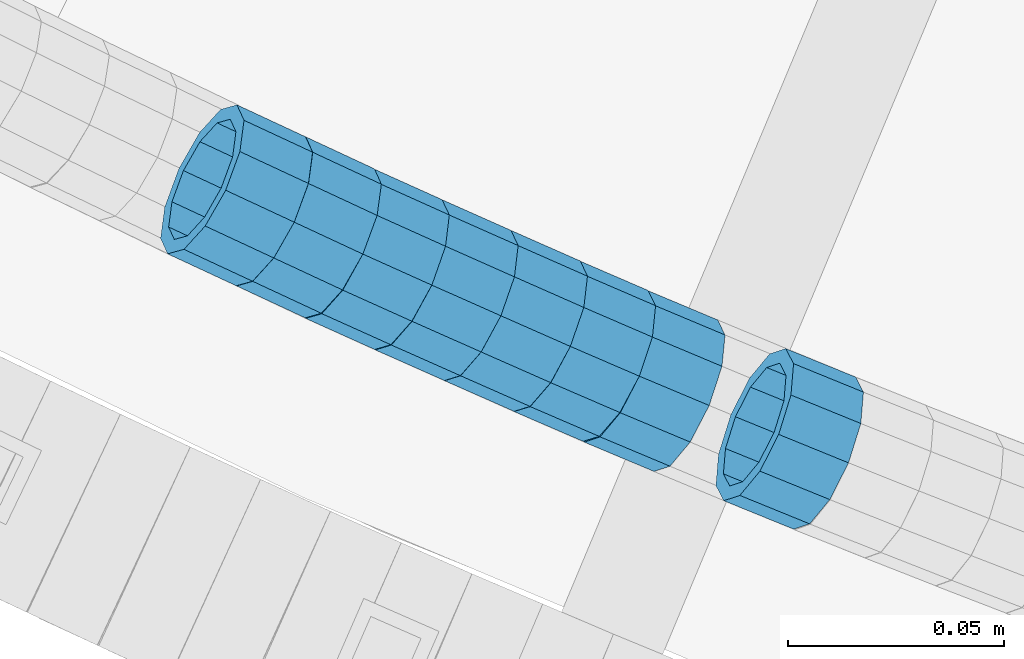
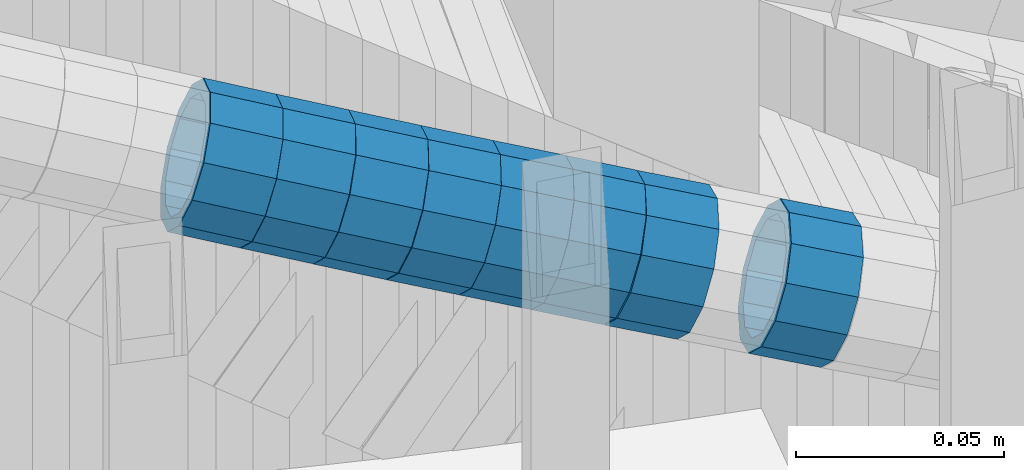
# One storey, part 648 of 975: 8 beams.
"""IFC2X3 building model written with IfcOpenShell, lengths in millimetres."""

from ifc_helpers import new_model, si_unit, frame, origin_with_axes, place, context, subcontext, project, spatial, faceted_brep, material, type_object, element, save


model = new_model("IFC2X3")

# Units and contexts
model_context = context("Model", 3, precision=1e-05, world=origin_with_axes())
body_context = subcontext(model_context, "Body", "Model", "MODEL_VIEW")
ifc_project = project(units=[si_unit("LENGTHUNIT", "METRE", prefix="MILLI"), si_unit("AREAUNIT", "SQUARE_METRE"), si_unit("VOLUMEUNIT", "CUBIC_METRE"), si_unit("MASSUNIT", "GRAM", prefix="KILO"), si_unit("TIMEUNIT", "SECOND"), si_unit("PLANEANGLEUNIT", "RADIAN"), si_unit("SOLIDANGLEUNIT", "STERADIAN"), si_unit("THERMODYNAMICTEMPERATUREUNIT", "DEGREE_CELSIUS"), si_unit("LUMINOUSINTENSITYUNIT", "LUMEN")], contexts=[model_context])

# Site, building, storey
site_placement = place(None, origin_with_axes())
site = spatial("IfcSite", under=ifc_project, at=site_placement, CompositionType="ELEMENT")
building_placement = place(site_placement, origin_with_axes())
building = spatial("IfcBuilding", under=site, at=building_placement, Name="Undefined", CompositionType="ELEMENT")
storey_placement = place(building_placement, origin_with_axes())
storey = spatial("IfcBuildingStorey", under=building, at=storey_placement, Name="Undefined", CompositionType="ELEMENT", Elevation=0.0)

# Beams
ifc_material = material()
beam_type = type_object("IfcBeamType", PredefinedType="NOTDEFINED")
beam_1_placement = place(storey_placement, frame((33541.3736434403, 884.03128961112, 4612.91343516353), z_axis=(0.421948777550613, 0.906619671705585, 9.36570359044708e-11), x_axis=(0.860768269091281, -0.400609131042504, -0.313990941033288)))
element("IfcBeam", 1, at=beam_1_placement, inside=storey, type_object=beam_type, material=ifc_material, Name="WALL", context=body_context, shape_type="Brep", body=[
    faceted_brep([(-2.1246523829177e-07, -15.367000000002, 0.0), (-1.83998054126278e-07, -13.3082123799541, 7.68350000000009), (18.4672683416502, -13.3082123799759, 7.68350000002465), (18.4672683416611, -15.3670000000202, 3.09228198602796e-11), (-1.06232619145885e-07, -7.68349999999919, 13.3082123799559), (18.467268341632, -7.68350000001737, 13.3082123799704), (-3.63797880709171e-12, 3.63797880709171e-12, 15.3670000000002), (18.4672683416175, -1.09139364212751e-11, 15.3670000000075), (1.06225343188271e-07, 7.68350000000646, 13.3082123799559), (18.4672683416102, 7.68349999998827, 13.3082123799613), (1.8399441614747e-07, 13.308212379965, 7.68350000000009), (18.4672683416138, 13.3082123799468, 7.68350000000464), (2.12461600312963e-07, 15.3670000000093, 0.0), (18.4672683416138, 15.3669999999929, 5.45696821063757e-12), (1.8399441614747e-07, 13.308212379965, -7.68350000000009), (18.4672683416284, 13.308212379945, -7.68349999998827), (1.06225343188271e-07, 7.68350000000646, -13.3082123799559), (18.4672683416429, 7.68349999998827, -13.3082123799359), (-3.63797880709171e-12, 3.63797880709171e-12, -15.3670000000002), (18.4672683416611, -1.63709046319127e-11, -15.3669999999747), (-1.06232619145885e-07, -7.68349999999919, -13.3082123799559), (18.4672683416647, -7.68350000001919, -13.3082123799268), (-1.83998054126278e-07, -13.3082123799541, -7.68350000000009), (18.4672683416684, -13.3082123799759, -7.68349999997008), (-2.63386027654633e-07, -19.0500000000029, 0.0), (-2.28097633225843e-07, -16.4977839420972, -9.52499999999964), (18.4672683416793, -16.4977839421172, -9.52499999996508), (18.467268341672, -19.0500000000247, 3.27418092638254e-11), (-1.31691194837913e-07, -9.52500000000146, -16.4977839420935), (18.4672683416757, -9.52500000002328, -16.497783942059), (-3.63797880709171e-12, 3.63797880709171e-12, -19.0500000000002), (18.4672683416611, -1.45519152283669e-11, -19.0499999999738), (1.31687556859106e-07, 9.52500000000509, -16.4977839420935), (18.4672683416502, 9.5249999999869, -16.4977839420735), (2.28097633225843e-07, 16.4977839421044, -9.52499999999964), (18.4672683416247, 16.4977839420862, -9.52499999998872), (2.63382389675826e-07, 19.0500000000138, 0.0), (18.4672683416029, 19.0499999999956, 1.81898940354586e-12), (2.28097633225843e-07, 16.4977839421044, 9.52499999999964), (18.4672683416065, 16.4977839420862, 9.52500000000146), (1.31687556859106e-07, 9.52500000000509, 16.4977839420935), (18.4672683415993, 9.52499999999236, 16.4977839420917), (-3.63797880709171e-12, 3.63797880709171e-12, 19.0500000000002), (18.4672683416138, -1.45519152283669e-11, 19.0500000000084), (-1.31691194837913e-07, -9.52500000000146, 16.4977839420935), (18.4672683416356, -9.52500000001783, 16.4977839421117), (-2.28097633225843e-07, -16.4977839420972, 9.52499999999964), (18.4672683416538, -16.4977839421135, 9.5250000000251)], [[[0, 1, 2, 3]], [[1, 4, 5, 2]], [[4, 6, 7, 5]], [[6, 8, 9, 7]], [[8, 10, 11, 9]], [[10, 12, 13, 11]], [[12, 14, 15, 13]], [[14, 16, 17, 15]], [[16, 18, 19, 17]], [[18, 20, 21, 19]], [[20, 22, 23, 21]], [[22, 0, 3, 23]], [[24, 25, 26, 27]], [[25, 28, 29, 26]], [[28, 30, 31, 29]], [[30, 32, 33, 31]], [[32, 34, 35, 33]], [[34, 36, 37, 35]], [[36, 38, 39, 37]], [[38, 40, 41, 39]], [[40, 42, 43, 41]], [[42, 44, 45, 43]], [[44, 46, 47, 45]], [[46, 24, 27, 47]], [[29, 31, 33, 35, 37, 39, 41, 43, 45, 47, 27, 26], [5, 7, 9, 11, 13, 15, 17, 19, 21, 23, 3, 2]], [[46, 44, 42, 40, 38, 36, 34, 32, 30, 28, 25, 24], [22, 20, 18, 16, 14, 12, 10, 8, 6, 4, 1, 0]]]),
])
beam_2_placement = place(storey_placement, frame((33557.3581390507, 876.591964610087, 4607.0828787991), z_axis=(0.421948777550613, 0.906619671705585, 9.36570359044708e-11), x_axis=(0.862222494829212, -0.401285940920517, -0.309098629938771)))
element("IfcBeam", 2, at=beam_2_placement, inside=storey, type_object=beam_type, material=ifc_material, Name="WALL", context=body_context, shape_type="Brep", body=[
    faceted_brep([(-2.1246523829177e-07, -15.367000000002, 0.0), (-1.83998054126278e-07, -13.3082123799541, 7.68350000000009), (18.4442402933746, -13.3082123799431, 7.68349999998463), (18.4442402933928, -15.3669999999893, -3.63797880709171e-12), (-1.06232619145885e-07, -7.68349999999919, 13.3082123799559), (18.4442402933564, -7.68349999998281, 13.308212379925), (-3.63797880709171e-12, 3.63797880709171e-12, 15.3670000000002), (18.4442402933455, 1.81898940354586e-11, 15.3669999999584), (1.06225343188271e-07, 7.68350000000646, 13.3082123799559), (18.4442402933419, 7.68350000001737, 13.3082123799104), (1.8399441614747e-07, 13.308212379965, 7.68350000000009), (18.4442402933528, 13.3082123799722, 7.68349999996281), (2.12461600312963e-07, 15.3670000000093, 0.0), (18.4442402933637, 15.3670000000129, -2.5465851649642e-11), (1.8399441614747e-07, 13.308212379965, -7.68350000000009), (18.4442402933855, 13.308212379965, -7.6835000000101), (1.06225343188271e-07, 7.68350000000646, -13.3082123799559), (18.4442402934037, 7.68350000000646, -13.3082123799541), (-3.63797880709171e-12, 3.63797880709171e-12, -15.3670000000002), (18.444240293411, 5.45696821063757e-12, -15.3669999999911), (-1.06232619145885e-07, -7.68349999999919, -13.3082123799559), (18.4442402934146, -7.68349999999373, -13.3082123799431), (-1.83998054126278e-07, -13.3082123799541, -7.68350000000009), (18.4442402934037, -13.3082123799468, -7.68349999999191), (-2.63386027654633e-07, -19.0500000000029, 0.0), (-2.28097633225843e-07, -16.4977839420972, -9.52499999999964), (18.444240293411, -16.4977839420862, -9.5249999999869), (18.4442402933964, -19.0499999999902, 0.0), (-1.31691194837913e-07, -9.52500000000146, -16.4977839420935), (18.4442402934219, -9.524999999996, -16.4977839420717), (-3.63797880709171e-12, 3.63797880709171e-12, -19.0500000000002), (18.4442402934183, 3.63797880709171e-12, -19.0499999999847), (1.31687556859106e-07, 9.52500000000509, -16.4977839420935), (18.4442402934073, 9.52500000000509, -16.4977839420899), (2.28097633225843e-07, 16.4977839421044, -9.52499999999964), (18.4442402933855, 16.4977839421008, -9.52500000001601), (2.63382389675826e-07, 19.0500000000138, 0.0), (18.4442402933637, 19.0500000000138, -2.91038304567337e-11), (2.28097633225843e-07, 16.4977839421044, 9.52499999999964), (18.4442402933419, 16.4977839421117, 9.52499999995052), (1.31687556859106e-07, 9.52500000000509, 16.4977839420935), (18.4442402933346, 9.52500000001965, 16.4977839420426), (-3.63797880709171e-12, 3.63797880709171e-12, 19.0500000000002), (18.4442402933346, 2.00088834390044e-11, 19.0499999999483), (-1.31691194837913e-07, -9.52500000000146, 16.4977839420935), (18.4442402933528, -9.52499999998145, 16.4977839420571), (-2.28097633225843e-07, -16.4977839420972, 9.52499999999964), (18.4442402933746, -16.497783942079, 9.52499999998327)], [[[0, 1, 2, 3]], [[1, 4, 5, 2]], [[4, 6, 7, 5]], [[6, 8, 9, 7]], [[8, 10, 11, 9]], [[10, 12, 13, 11]], [[12, 14, 15, 13]], [[14, 16, 17, 15]], [[16, 18, 19, 17]], [[18, 20, 21, 19]], [[20, 22, 23, 21]], [[22, 0, 3, 23]], [[24, 25, 26, 27]], [[25, 28, 29, 26]], [[28, 30, 31, 29]], [[30, 32, 33, 31]], [[32, 34, 35, 33]], [[34, 36, 37, 35]], [[36, 38, 39, 37]], [[38, 40, 41, 39]], [[40, 42, 43, 41]], [[42, 44, 45, 43]], [[44, 46, 47, 45]], [[46, 24, 27, 47]], [[29, 31, 33, 35, 37, 39, 41, 43, 45, 47, 27, 26], [5, 7, 9, 11, 13, 15, 17, 19, 21, 23, 3, 2]], [[46, 44, 42, 40, 38, 36, 34, 32, 30, 28, 25, 24], [22, 20, 18, 16, 14, 12, 10, 8, 6, 4, 1, 0]]]),
])
beam_3_placement = place(storey_placement, frame((33573.1440872467, 869.161028404244, 4601.41265312661), z_axis=(0.410364677821591, 0.911921504953349, -2.54000951827038e-10), x_axis=(0.865839403247005, -0.389627732111212, -0.313866784089593)))
element("IfcBeam", 3, at=beam_3_placement, inside=storey, type_object=beam_type, material=ifc_material, Name="WALL", context=body_context, shape_type="Brep", body=[
    faceted_brep([(-2.1246523829177e-07, -15.367000000002, 0.0), (-1.83998054126278e-07, -13.3082123799541, 7.68350000000009), (18.4753890351749, -13.3082123799613, 7.6835000000101), (18.4753890351676, -15.3670000000056, 0.0), (-1.06232619145885e-07, -7.68349999999919, 13.3082123799559), (18.4753890351822, -7.6835000000101, 13.3082123799686), (-3.63797880709171e-12, 3.63797880709171e-12, 15.3670000000002), (18.4753890351967, -1.2732925824821e-11, 15.3670000000238), (1.06225343188271e-07, 7.68350000000646, 13.3082123799559), (18.475389035204, 7.68349999998463, 13.3082123799832), (1.8399441614747e-07, 13.308212379965, 7.68350000000009), (18.4753890352004, 13.3082123799395, 7.68350000002465), (2.12461600312963e-07, 15.3670000000093, 0.0), (18.4753890351967, 15.3669999999838, 2.5465851649642e-11), (1.8399441614747e-07, 13.308212379965, -7.68350000000009), (18.4753890351894, 13.3082123799413, -7.68349999998463), (1.06225343188271e-07, 7.68350000000646, -13.3082123799559), (18.4753890351749, 7.68349999998827, -13.3082123799468), (-3.63797880709171e-12, 3.63797880709171e-12, -15.3670000000002), (18.4753890351676, -1.09139364212751e-11, -15.3669999999947), (-1.06232619145885e-07, -7.68349999999919, -13.3082123799559), (18.4753890351676, -7.68350000000646, -13.3082123799577), (-1.83998054126278e-07, -13.3082123799541, -7.68350000000009), (18.4753890351567, -13.3082123799613, -7.68350000000282), (-2.63386027654633e-07, -19.0500000000029, 0.0), (-2.28097633225843e-07, -16.4977839420972, -9.52499999999964), (18.4753890351567, -16.4977839420972, -9.52500000000873), (18.4753890351676, -19.0500000000065, 0.0), (-1.31691194837913e-07, -9.52500000000146, -16.4977839420935), (18.475389035164, -9.52500000000873, -16.4977839420972), (-3.63797880709171e-12, 3.63797880709171e-12, -19.0500000000002), (18.475389035164, -9.09494701772928e-12, -19.0499999999993), (1.31687556859106e-07, 9.52500000000509, -16.4977839420935), (18.4753890351822, 9.5249999999869, -16.497783942079), (2.28097633225843e-07, 16.4977839421044, -9.52499999999964), (18.4753890351931, 16.497783942079, -9.52499999997963), (2.63382389675826e-07, 19.0500000000138, 0.0), (18.475389035204, 19.0499999999847, 2.91038304567337e-11), (2.28097633225843e-07, 16.4977839421044, 9.52499999999964), (18.4753890352113, 16.4977839420753, 9.5250000000342), (1.31687556859106e-07, 9.52500000000509, 16.4977839420935), (18.475389035204, 9.52499999998327, 16.4977839421226), (-3.63797880709171e-12, 3.63797880709171e-12, 19.0500000000002), (18.4753890352004, -1.45519152283669e-11, 19.0500000000284), (-1.31691194837913e-07, -9.52500000000146, 16.4977839420935), (18.4753890351858, -9.52500000000873, 16.4977839421081), (-2.28097633225843e-07, -16.4977839420972, 9.52499999999964), (18.4753890351749, -16.4977839421008, 9.52500000000509)], [[[0, 1, 2, 3]], [[1, 4, 5, 2]], [[4, 6, 7, 5]], [[6, 8, 9, 7]], [[8, 10, 11, 9]], [[10, 12, 13, 11]], [[12, 14, 15, 13]], [[14, 16, 17, 15]], [[16, 18, 19, 17]], [[18, 20, 21, 19]], [[20, 22, 23, 21]], [[22, 0, 3, 23]], [[24, 25, 26, 27]], [[25, 28, 29, 26]], [[28, 30, 31, 29]], [[30, 32, 33, 31]], [[32, 34, 35, 33]], [[34, 36, 37, 35]], [[36, 38, 39, 37]], [[38, 40, 41, 39]], [[40, 42, 43, 41]], [[42, 44, 45, 43]], [[44, 46, 47, 45]], [[46, 24, 27, 47]], [[29, 31, 33, 35, 37, 39, 41, 43, 45, 47, 27, 26], [5, 7, 9, 11, 13, 15, 17, 19, 21, 23, 3, 2]], [[46, 44, 42, 40, 38, 36, 34, 32, 30, 28, 25, 24], [22, 20, 18, 16, 14, 12, 10, 8, 6, 4, 1, 0]]]),
])
beam_4_placement = place(storey_placement, frame((33589.2052013027, 861.899830750522, 4595.58615439717), z_axis=(0.4056083450675, 0.914046973853972, -3.93774826079607e-11), x_axis=(0.86912891386742, -0.385675955941177, -0.309627175952788)))
element("IfcBeam", 4, at=beam_4_placement, inside=storey, type_object=beam_type, material=ifc_material, Name="WALL", context=body_context, shape_type="Brep", body=[
    faceted_brep([(-2.1246523829177e-07, -15.367000000002, 0.0), (-1.83998054126278e-07, -13.3082123799541, 7.68350000000009), (18.4143965418989, -13.3082123799722, 7.68350000004284), (18.4143965419134, -15.3670000000257, 5.82076609134674e-11), (-1.06232619145885e-07, -7.68349999999919, 13.3082123799559), (18.4143965418734, -7.68350000000646, 13.3082123799759), (-3.63797880709171e-12, 3.63797880709171e-12, 15.3670000000002), (18.414396541848, 3.63797880709171e-12, 15.3669999999984), (1.06225343188271e-07, 7.68350000000646, 13.3082123799559), (18.4143965418334, 7.6835000000101, 13.3082123799395), (1.8399441614747e-07, 13.308212379965, 7.68350000000009), (18.4143965418261, 13.3082123799686, 7.68349999997736), (2.12461600312963e-07, 15.3670000000093, 0.0), (18.4143965418334, 15.3670000000093, -1.81898940354586e-11), (1.8399441614747e-07, 13.308212379965, -7.68350000000009), (18.4143965418552, 13.3082123799577, -7.68349999999919), (1.06225343188271e-07, 7.68350000000646, -13.3082123799559), (18.4143965418734, 7.68349999999191, -13.3082123799322), (-3.63797880709171e-12, 3.63797880709171e-12, -15.3670000000002), (18.4143965418989, -2.00088834390044e-11, -15.3669999999584), (-1.06232619145885e-07, -7.68349999999919, -13.3082123799559), (18.4143965419134, -7.68350000002829, -13.3082123798958), (-1.83998054126278e-07, -13.3082123799541, -7.68350000000009), (18.4143965419207, -13.3082123799832, -7.6834999999337), (-2.63386027654633e-07, -19.0500000000029, 0.0), (-2.28097633225843e-07, -16.4977839420972, -9.52499999999964), (18.4143965419316, -16.4977839421263, -9.5249999999287), (18.4143965419207, -19.0500000000284, 6.54836185276508e-11), (-1.31691194837913e-07, -9.52500000000146, -16.4977839420935), (18.4143965419207, -9.52500000003056, -16.497783942028), (-3.63797880709171e-12, 3.63797880709171e-12, -19.0500000000002), (18.4143965419025, -2.18278728425503e-11, -19.049999999952), (1.31687556859106e-07, 9.52500000000509, -16.4977839420935), (18.4143965418771, 9.52499999999054, -16.4977839420717), (2.28097633225843e-07, 16.4977839421044, -9.52499999999964), (18.414396541848, 16.4977839420972, -9.52500000000146), (2.63382389675826e-07, 19.0500000000138, 0.0), (18.4143965418298, 19.050000000012, -2.18278728425503e-11), (2.28097633225843e-07, 16.4977839421044, 9.52499999999964), (18.4143965418225, 16.4977839421117, 9.52499999997235), (1.31687556859106e-07, 9.52500000000509, 16.4977839420935), (18.4143965418225, 9.52500000001601, 16.4977839420681), (-3.63797880709171e-12, 3.63797880709171e-12, 19.0500000000002), (18.4143965418443, 7.27595761418343e-12, 19.0499999999956), (-1.31691194837913e-07, -9.52500000000146, 16.4977839420935), (18.4143965418734, -9.52500000000691, 16.4977839421153), (-2.28097633225843e-07, -16.4977839420972, 9.52499999999964), (18.4143965418989, -16.4977839421117, 9.52500000004511)], [[[0, 1, 2, 3]], [[1, 4, 5, 2]], [[4, 6, 7, 5]], [[6, 8, 9, 7]], [[8, 10, 11, 9]], [[10, 12, 13, 11]], [[12, 14, 15, 13]], [[14, 16, 17, 15]], [[16, 18, 19, 17]], [[18, 20, 21, 19]], [[20, 22, 23, 21]], [[22, 0, 3, 23]], [[24, 25, 26, 27]], [[25, 28, 29, 26]], [[28, 30, 31, 29]], [[30, 32, 33, 31]], [[32, 34, 35, 33]], [[34, 36, 37, 35]], [[36, 38, 39, 37]], [[38, 40, 41, 39]], [[40, 42, 43, 41]], [[42, 44, 45, 43]], [[44, 46, 47, 45]], [[46, 24, 27, 47]], [[29, 31, 33, 35, 37, 39, 41, 43, 45, 47, 27, 26], [5, 7, 9, 11, 13, 15, 17, 19, 21, 23, 3, 2]], [[46, 44, 42, 40, 38, 36, 34, 32, 30, 28, 25, 24], [22, 20, 18, 16, 14, 12, 10, 8, 6, 4, 1, 0]]]),
])
beam_5_placement = place(storey_placement, frame((33605.2250799293, 854.776204528065, 4589.87714576763), z_axis=(0.403500285105002, 0.914979518852844, -5.03569026477635e-11), x_axis=(0.870448320239563, -0.383862303105652, -0.30817114408482)))
element("IfcBeam", 5, at=beam_5_placement, inside=storey, type_object=beam_type, material=ifc_material, Name="WALL", context=body_context, shape_type="Brep", body=[
    faceted_brep([(-2.1246523829177e-07, -15.367000000002, 0.0), (-1.83998054126278e-07, -13.3082123799541, 7.68350000000009), (18.5005405327211, -13.3082123799777, 7.68350000005012), (18.5005405327393, -15.3670000000293, 6.54836185276508e-11), (-1.06232619145885e-07, -7.68349999999919, 13.3082123799559), (18.5005405326992, -7.68350000001737, 13.3082123799904), (-3.63797880709171e-12, 3.63797880709171e-12, 15.3670000000002), (18.5005405326847, -1.2732925824821e-11, 15.3670000000238), (1.06225343188271e-07, 7.68350000000646, 13.3082123799559), (18.5005405326665, 7.68349999999009, 13.308212379965), (1.8399441614747e-07, 13.308212379965, 7.68350000000009), (18.5005405326592, 13.3082123799468, 7.68349999999919), (2.12461600312963e-07, 15.3670000000093, 0.0), (18.5005405326629, 15.3669999999893, 7.27595761418343e-12), (1.8399441614747e-07, 13.308212379965, -7.68350000000009), (18.5005405326738, 13.3082123799413, -7.683499999981), (1.06225343188271e-07, 7.68350000000646, -13.3082123799559), (18.500540532692, 7.68349999997736, -13.3082123799177), (-3.63797880709171e-12, 3.63797880709171e-12, -15.3670000000002), (18.5005405327211, -2.91038304567337e-11, -15.3669999999438), (-1.06232619145885e-07, -7.68349999999919, -13.3082123799559), (18.500540532732, -7.68350000003375, -13.3082123798886), (-1.83998054126278e-07, -13.3082123799541, -7.68350000000009), (18.5005405327429, -13.3082123799886, -7.68349999992643), (-2.63386027654633e-07, -19.0500000000029, 0.0), (-2.28097633225843e-07, -16.4977839420972, -9.52499999999964), (18.5005405327502, -16.4977839421281, -9.52499999991778), (18.5005405327465, -19.0500000000338, 7.27595761418343e-11), (-1.31691194837913e-07, -9.52500000000146, -16.4977839420935), (18.5005405327429, -9.52500000003602, -16.4977839420171), (-3.63797880709171e-12, 3.63797880709171e-12, -19.0500000000002), (18.5005405327211, -3.09228198602796e-11, -19.0499999999411), (1.31687556859106e-07, 9.52500000000509, -16.4977839420935), (18.500540532692, 9.52499999997599, -16.4977839420571), (2.28097633225843e-07, 16.4977839421044, -9.52499999999964), (18.5005405326701, 16.4977839420771, -9.52499999998327), (2.63382389675826e-07, 19.0500000000138, 0.0), (18.5005405326519, 19.0499999999902, 0.0), (2.28097633225843e-07, 16.4977839421044, 9.52499999999964), (18.5005405326447, 16.4977839420881, 9.52499999999418), (1.31687556859106e-07, 9.52500000000509, 16.4977839420935), (18.5005405326556, 9.524999999996, 16.4977839420899), (-3.63797880709171e-12, 3.63797880709171e-12, 19.0500000000002), (18.5005405326738, -9.09494701772928e-12, 19.0500000000138), (-1.31691194837913e-07, -9.52500000000146, 16.4977839420935), (18.5005405327065, -9.52500000001783, 16.4977839421335), (-2.28097633225843e-07, -16.4977839420972, 9.52499999999964), (18.5005405327247, -16.497783942119, 9.52500000005602)], [[[0, 1, 2, 3]], [[1, 4, 5, 2]], [[4, 6, 7, 5]], [[6, 8, 9, 7]], [[8, 10, 11, 9]], [[10, 12, 13, 11]], [[12, 14, 15, 13]], [[14, 16, 17, 15]], [[16, 18, 19, 17]], [[18, 20, 21, 19]], [[20, 22, 23, 21]], [[22, 0, 3, 23]], [[24, 25, 26, 27]], [[25, 28, 29, 26]], [[28, 30, 31, 29]], [[30, 32, 33, 31]], [[32, 34, 35, 33]], [[34, 36, 37, 35]], [[36, 38, 39, 37]], [[38, 40, 41, 39]], [[40, 42, 43, 41]], [[42, 44, 45, 43]], [[44, 46, 47, 45]], [[46, 24, 27, 47]], [[29, 31, 33, 35, 37, 39, 41, 43, 45, 47, 27, 26], [5, 7, 9, 11, 13, 15, 17, 19, 21, 23, 3, 2]], [[46, 44, 42, 40, 38, 36, 34, 32, 30, 28, 25, 24], [22, 20, 18, 16, 14, 12, 10, 8, 6, 4, 1, 0]]]),
])
beam_6_placement = place(storey_placement, frame((33621.1719108021, 847.689919621833, 4584.22505288164), z_axis=(0.395996232929544, 0.91825213504005, 2.68146322923712e-11), x_axis=(0.871252432175876, -0.37572761107583, -0.315829007063744)))
element("IfcBeam", 6, at=beam_6_placement, inside=storey, type_object=beam_type, material=ifc_material, Name="WALL", context=body_context, shape_type="Brep", body=[
    faceted_brep([(-2.1246523829177e-07, -15.367000000002, 0.0), (-1.83998054126278e-07, -13.3082123799541, 7.68350000000009), (18.361644806515, -13.308212379945, 7.68349999999555), (18.3616448065295, -15.3669999999893, 7.27595761418343e-12), (-1.06232619145885e-07, -7.68349999999919, 13.3082123799559), (18.3616448064895, -7.68349999998281, 13.3082123799359), (-3.63797880709171e-12, 3.63797880709171e-12, 15.3670000000002), (18.3616448064713, 2.00088834390044e-11, 15.3669999999729), (1.06225343188271e-07, 7.68350000000646, 13.3082123799559), (18.361644806464, 7.68350000001919, 13.3082123799213), (1.8399441614747e-07, 13.308212379965, 7.68350000000009), (18.3616448064568, 13.3082123799777, 7.68349999996644), (2.12461600312963e-07, 15.3670000000093, 0.0), (18.361644806464, 15.3670000000202, -3.27418092638254e-11), (1.8399441614747e-07, 13.308212379965, -7.68350000000009), (18.3616448064822, 13.3082123799704, -7.68350000002101), (1.06225343188271e-07, 7.68350000000646, -13.3082123799559), (18.361644806504, 7.68350000001192, -13.308212379965), (-3.63797880709171e-12, 3.63797880709171e-12, -15.3670000000002), (18.3616448065259, 9.09494701772928e-12, -15.3669999999984), (-1.06232619145885e-07, -7.68349999999919, -13.3082123799559), (18.3616448065368, -7.68349999999373, -13.3082123799431), (-1.83998054126278e-07, -13.3082123799541, -7.68350000000009), (18.3616448065441, -13.3082123799486, -7.68349999998827), (-2.63386027654633e-07, -19.0500000000029, 0.0), (-2.28097633225843e-07, -16.4977839420972, -9.52499999999964), (18.3616448065477, -16.4977839420881, -9.52499999998327), (18.3616448065441, -19.049999999992, 1.09139364212751e-11), (-1.31691194837913e-07, -9.52500000000146, -16.4977839420935), (18.3616448065477, -9.52499999999236, -16.4977839420753), (-3.63797880709171e-12, 3.63797880709171e-12, -19.0500000000002), (18.3616448065295, 9.09494701772928e-12, -19.049999999992), (1.31687556859106e-07, 9.52500000000509, -16.4977839420935), (18.3616448065077, 9.52500000001055, -16.4977839420972), (2.28097633225843e-07, 16.4977839421044, -9.52499999999964), (18.3616448064786, 16.4977839421099, -9.52500000002328), (2.63382389675826e-07, 19.0500000000138, 0.0), (18.3616448064531, 19.0500000000193, -3.63797880709171e-11), (2.28097633225843e-07, 16.4977839421044, 9.52499999999964), (18.3616448064458, 16.4977839421172, 9.5249999999578), (1.31687556859106e-07, 9.52500000000509, 16.4977839420935), (18.3616448064495, 9.52500000002328, 16.4977839420571), (-3.63797880709171e-12, 3.63797880709171e-12, 19.0500000000002), (18.361644806464, 2.18278728425503e-11, 19.0499999999665), (-1.31691194837913e-07, -9.52500000000146, 16.4977839420935), (18.3616448064895, -9.52499999998145, 16.497783942079), (-2.28097633225843e-07, -16.4977839420972, 9.52499999999964), (18.361644806515, -16.4977839420808, 9.52499999999782)], [[[0, 1, 2, 3]], [[1, 4, 5, 2]], [[4, 6, 7, 5]], [[6, 8, 9, 7]], [[8, 10, 11, 9]], [[10, 12, 13, 11]], [[12, 14, 15, 13]], [[14, 16, 17, 15]], [[16, 18, 19, 17]], [[18, 20, 21, 19]], [[20, 22, 23, 21]], [[22, 0, 3, 23]], [[24, 25, 26, 27]], [[25, 28, 29, 26]], [[28, 30, 31, 29]], [[30, 32, 33, 31]], [[32, 34, 35, 33]], [[34, 36, 37, 35]], [[36, 38, 39, 37]], [[38, 40, 41, 39]], [[40, 42, 43, 41]], [[42, 44, 45, 43]], [[44, 46, 47, 45]], [[46, 24, 27, 47]], [[29, 31, 33, 35, 37, 39, 41, 43, 45, 47, 27, 26], [5, 7, 9, 11, 13, 15, 17, 19, 21, 23, 3, 2]], [[46, 44, 42, 40, 38, 36, 34, 32, 30, 28, 25, 24], [22, 20, 18, 16, 14, 12, 10, 8, 6, 4, 1, 0]]]),
])
beam_7_placement = place(storey_placement, frame((33637.2760410037, 840.682693614661, 4578.37976579427), z_axis=(0.38703894507241, 0.922063368211337, 4.87671059090644e-12), x_axis=(0.877060589859579, -0.368148889941072, -0.308595392950582)))
element("IfcBeam", 7, at=beam_7_placement, inside=storey, type_object=beam_type, material=ifc_material, Name="WALL", context=body_context, shape_type="Brep", body=[
    faceted_brep([(-2.1246523829177e-07, -15.367000000002, 0.0), (-1.83998054126278e-07, -13.3082123799541, 7.68350000000009), (18.4672683416502, -13.3082123799759, 7.68350000002465), (18.4672683416611, -15.3670000000202, 3.09228198602796e-11), (-1.06232619145885e-07, -7.68349999999919, 13.3082123799559), (18.467268341632, -7.68350000001737, 13.3082123799704), (-3.63797880709171e-12, 3.63797880709171e-12, 15.3670000000002), (18.4672683416175, -1.09139364212751e-11, 15.3670000000075), (1.06225343188271e-07, 7.68350000000646, 13.3082123799559), (18.4672683416102, 7.68349999998827, 13.3082123799613), (1.8399441614747e-07, 13.308212379965, 7.68350000000009), (18.4672683416138, 13.3082123799468, 7.68350000000464), (2.12461600312963e-07, 15.3670000000093, 0.0), (18.4672683416138, 15.3669999999929, 5.45696821063757e-12), (1.8399441614747e-07, 13.308212379965, -7.68350000000009), (18.4672683416284, 13.308212379945, -7.68349999998827), (1.06225343188271e-07, 7.68350000000646, -13.3082123799559), (18.4672683416429, 7.68349999998827, -13.3082123799359), (-3.63797880709171e-12, 3.63797880709171e-12, -15.3670000000002), (18.4672683416611, -1.63709046319127e-11, -15.3669999999747), (-1.06232619145885e-07, -7.68349999999919, -13.3082123799559), (18.4672683416647, -7.68350000001919, -13.3082123799268), (-1.83998054126278e-07, -13.3082123799541, -7.68350000000009), (18.4672683416684, -13.3082123799759, -7.68349999997008), (-2.63386027654633e-07, -19.0500000000029, 0.0), (-2.28097633225843e-07, -16.4977839420972, -9.52499999999964), (18.4672683416793, -16.4977839421172, -9.52499999996508), (18.467268341672, -19.0500000000247, 3.27418092638254e-11), (-1.31691194837913e-07, -9.52500000000146, -16.4977839420935), (18.4672683416757, -9.52500000002328, -16.497783942059), (-3.63797880709171e-12, 3.63797880709171e-12, -19.0500000000002), (18.4672683416611, -1.45519152283669e-11, -19.0499999999738), (1.31687556859106e-07, 9.52500000000509, -16.4977839420935), (18.4672683416502, 9.5249999999869, -16.4977839420735), (2.28097633225843e-07, 16.4977839421044, -9.52499999999964), (18.4672683416247, 16.4977839420862, -9.52499999998872), (2.63382389675826e-07, 19.0500000000138, 0.0), (18.4672683416029, 19.0499999999956, 1.81898940354586e-12), (2.28097633225843e-07, 16.4977839421044, 9.52499999999964), (18.4672683416065, 16.4977839420862, 9.52500000000146), (1.31687556859106e-07, 9.52500000000509, 16.4977839420935), (18.4672683415993, 9.52499999999236, 16.4977839420917), (-3.63797880709171e-12, 3.63797880709171e-12, 19.0500000000002), (18.4672683416138, -1.45519152283669e-11, 19.0500000000084), (-1.31691194837913e-07, -9.52500000000146, 16.4977839420935), (18.4672683416356, -9.52500000001783, 16.4977839421117), (-2.28097633225843e-07, -16.4977839420972, 9.52499999999964), (18.4672683416538, -16.4977839421135, 9.5250000000251)], [[[0, 1, 2, 3]], [[1, 4, 5, 2]], [[4, 6, 7, 5]], [[6, 8, 9, 7]], [[8, 10, 11, 9]], [[10, 12, 13, 11]], [[12, 14, 15, 13]], [[14, 16, 17, 15]], [[16, 18, 19, 17]], [[18, 20, 21, 19]], [[20, 22, 23, 21]], [[22, 0, 3, 23]], [[24, 25, 26, 27]], [[25, 28, 29, 26]], [[28, 30, 31, 29]], [[30, 32, 33, 31]], [[32, 34, 35, 33]], [[34, 36, 37, 35]], [[36, 38, 39, 37]], [[38, 40, 41, 39]], [[40, 42, 43, 41]], [[42, 44, 45, 43]], [[44, 46, 47, 45]], [[46, 24, 27, 47]], [[29, 31, 33, 35, 37, 39, 41, 43, 45, 47, 27, 26], [5, 7, 9, 11, 13, 15, 17, 19, 21, 23, 3, 2]], [[46, 44, 42, 40, 38, 36, 34, 32, 30, 28, 25, 24], [22, 20, 18, 16, 14, 12, 10, 8, 6, 4, 1, 0]]]),
])
beam_8_placement = place(storey_placement, frame((33669.4443786218, 827.169413191701, 4567.01800787504), z_axis=(0.377296887248761, 0.926092359795931, -1.01913428807165e-10), x_axis=(0.879033848323888, -0.358124901131953, -0.31471582211596)))
element("IfcBeam", 8, at=beam_8_placement, inside=storey, type_object=beam_type, material=ifc_material, Name="WALL", context=body_context, shape_type="Brep", body=[
    faceted_brep([(-2.1246523829177e-07, -15.367000000002, 0.0), (-1.83998054126278e-07, -13.3082123799541, 7.68350000000009), (18.428781837134, -13.3082123799413, 7.68349999998827), (18.4287818371195, -15.3669999999802, -2.5465851649642e-11), (-1.06232619145885e-07, -7.68349999999919, 13.3082123799559), (18.4287818371522, -7.68349999999373, 13.3082123799577), (-3.63797880709171e-12, 3.63797880709171e-12, 15.3670000000002), (18.4287818371486, 5.45696821063757e-12, 15.367000000002), (1.06225343188271e-07, 7.68350000000646, 13.3082123799559), (18.4287818371558, 7.68350000000282, 13.3082123799577), (1.8399441614747e-07, 13.308212379965, 7.68350000000009), (18.4287818371413, 13.3082123799595, 7.68349999999191), (2.12461600312963e-07, 15.3670000000093, 0.0), (18.4287818371267, 15.3670000000075, -2.18278728425503e-11), (1.8399441614747e-07, 13.308212379965, -7.68350000000009), (18.4287818371122, 13.3082123799668, -7.68350000003193), (1.06225343188271e-07, 7.68350000000646, -13.3082123799559), (18.4287818370976, 7.68350000001737, -13.3082123800014), (-3.63797880709171e-12, 3.63797880709171e-12, -15.3670000000002), (18.428781837094, 2.00088834390044e-11, -15.3670000000529), (-1.06232619145885e-07, -7.68349999999919, -13.3082123799559), (18.4287818370976, -7.68349999997554, -13.308212380005), (-1.83998054126278e-07, -13.3082123799541, -7.68350000000009), (18.4287818371085, -13.308212379934, -7.6835000000392), (-2.63386027654633e-07, -19.0500000000029, 0.0), (-2.28097633225843e-07, -16.4977839420972, -9.52499999999964), (18.4287818371049, -16.4977839420699, -9.52500000004511), (18.4287818371231, -19.0499999999793, -2.5465851649642e-11), (-1.31691194837913e-07, -9.52500000000146, -16.4977839420935), (18.4287818370904, -9.52499999997599, -16.4977839421445), (-3.63797880709171e-12, 3.63797880709171e-12, -19.0500000000002), (18.4287818370831, 2.36468622460961e-11, -19.0500000000611), (1.31687556859106e-07, 9.52500000000509, -16.4977839420935), (18.4287818370904, 9.52500000001965, -16.4977839421481), (2.28097633225843e-07, 16.4977839421044, -9.52499999999964), (18.4287818371049, 16.4977839421063, -9.52500000004147), (2.63382389675826e-07, 19.0500000000138, 0.0), (18.4287818371304, 19.0500000000047, -2.18278728425503e-11), (2.28097633225843e-07, 16.4977839421044, 9.52499999999964), (18.4287818371486, 16.4977839420953, 9.52499999999782), (1.31687556859106e-07, 9.52500000000509, 16.4977839420935), (18.4287818371558, 9.52500000000146, 16.4977839421044), (-3.63797880709171e-12, 3.63797880709171e-12, 19.0500000000002), (18.4287818371631, 1.81898940354586e-12, 19.0500000000138), (-1.31691194837913e-07, -9.52500000000146, 16.4977839420935), (18.4287818371595, -9.52499999999236, 16.4977839421044), (-2.28097633225843e-07, -16.4977839420972, 9.52499999999964), (18.4287818371449, -16.4977839420808, 9.52499999999418)], [[[0, 1, 2, 3]], [[1, 4, 5, 2]], [[4, 6, 7, 5]], [[6, 8, 9, 7]], [[8, 10, 11, 9]], [[10, 12, 13, 11]], [[12, 14, 15, 13]], [[14, 16, 17, 15]], [[16, 18, 19, 17]], [[18, 20, 21, 19]], [[20, 22, 23, 21]], [[22, 0, 3, 23]], [[24, 25, 26, 27]], [[25, 28, 29, 26]], [[28, 30, 31, 29]], [[30, 32, 33, 31]], [[32, 34, 35, 33]], [[34, 36, 37, 35]], [[36, 38, 39, 37]], [[38, 40, 41, 39]], [[40, 42, 43, 41]], [[42, 44, 45, 43]], [[44, 46, 47, 45]], [[46, 24, 27, 47]], [[29, 31, 33, 35, 37, 39, 41, 43, 45, 47, 27, 26], [5, 7, 9, 11, 13, 15, 17, 19, 21, 23, 3, 2]], [[46, 44, 42, 40, 38, 36, 34, 32, 30, 28, 25, 24], [22, 20, 18, 16, 14, 12, 10, 8, 6, 4, 1, 0]]]),
])

save(model, "model.ifc")
